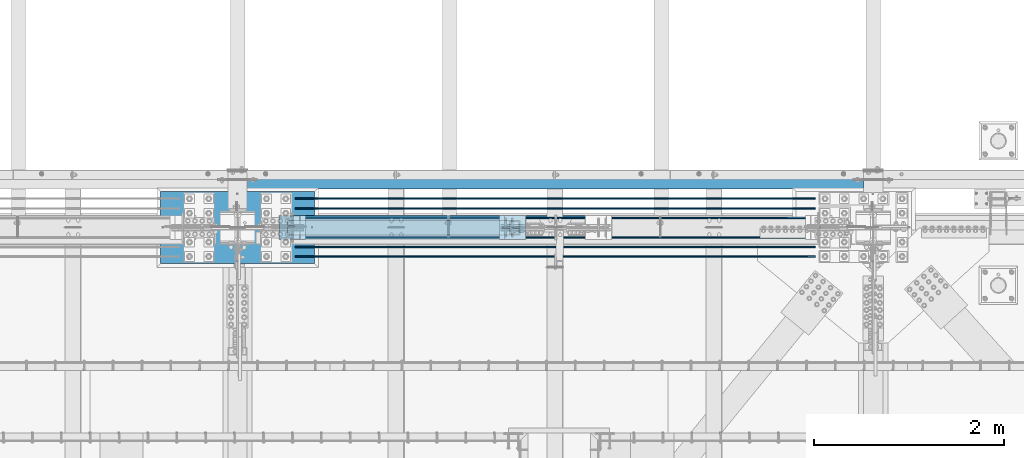
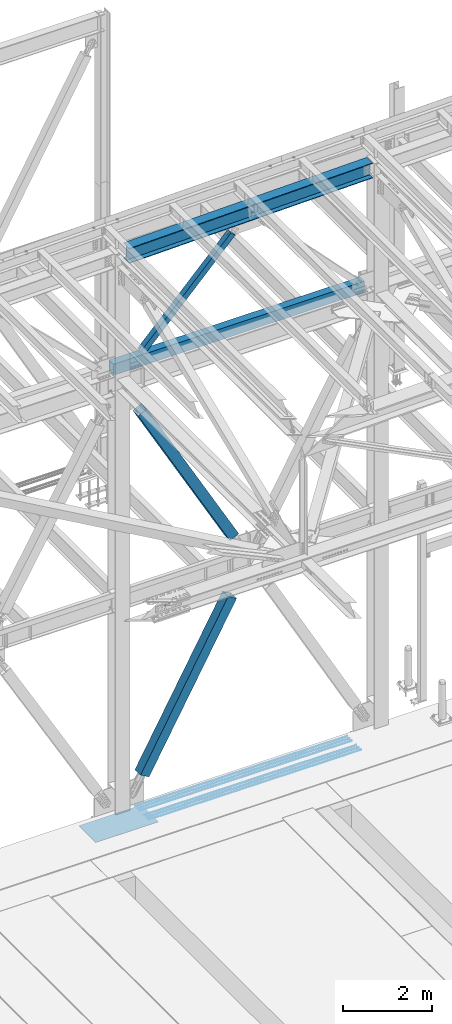
# One storey, part 1918 of 3843: 9 beams, 3 members, 12 elements without a shape of their own.
"""IFC2X3 building model written with IfcOpenShell, lengths in millimetres."""

from ifc_helpers import new_model, si_unit, frame, origin_with_axes, place, context, subcontext, project, spatial, faceted_brep, material, type_object, element, aggregate, save


model = new_model("IFC2X3")

# Units and contexts
model_context = context("Model", 3, precision=1e-05, world=origin_with_axes())
body_context = subcontext(model_context, "Body", "Model", "MODEL_VIEW")
ifc_project = project(units=[si_unit("LENGTHUNIT", "METRE", prefix="MILLI"), si_unit("AREAUNIT", "SQUARE_METRE"), si_unit("VOLUMEUNIT", "CUBIC_METRE"), si_unit("MASSUNIT", "GRAM", prefix="KILO"), si_unit("TIMEUNIT", "SECOND"), si_unit("PLANEANGLEUNIT", "RADIAN"), si_unit("SOLIDANGLEUNIT", "STERADIAN"), si_unit("THERMODYNAMICTEMPERATUREUNIT", "DEGREE_CELSIUS"), si_unit("LUMINOUSINTENSITYUNIT", "LUMEN")], contexts=[model_context])

# Site, building, storey
site_placement = place(None, origin_with_axes())
site = spatial("IfcSite", under=ifc_project, at=site_placement, CompositionType="ELEMENT")
building_placement = place(site_placement, origin_with_axes())
building = spatial("IfcBuilding", under=site, at=building_placement, Name="Undefined", CompositionType="ELEMENT")
storey_placement = place(building_placement, origin_with_axes())
storey = spatial("IfcBuildingStorey", under=building, at=storey_placement, Name="Undefined", CompositionType="ELEMENT", Elevation=0.0)

# Assembly, beam
assembly_1_placement = place(storey_placement, origin_with_axes())
assembly_1 = element("IfcElementAssembly", 1, at=assembly_1_placement, inside=storey, Name="REBAR", AssemblyPlace="NOTDEFINED", PredefinedType="RIGID_FRAME")
ifc_material_1 = material(Name="STEEL/A706-60")
beam_type_1 = type_object("IfcBeamType", Name="#10 REBAR", PredefinedType="NOTDEFINED")
beam_1_placement = place(assembly_1_placement, frame((56540.381606967, 91909.900012207, 30157.7375212653), z_axis=(0.00231477199979418, 0.0, 0.999997320911706), x_axis=(0.999997320911706, 0.0, -0.00231477199979557)))
beam_1 = element("IfcBeam", 2, at=beam_1_placement, type_object=beam_type_1, material=ifc_material_1, Name="REBAR", ObjectType="#10 REBAR", context=body_context, shape_type="Brep", body=[
    faceted_brep([(0.0, -7.9375, 0.0), (0.0, -5.61266007566883, -5.61266007566883), (5486.50219881769, -5.61266007566883, -5.61266006854567), (5486.50219881768, -7.9375, 7.12316250428557e-09), (0.0, 0.0, -7.9375), (5486.50219881769, 0.0, -7.93749999287684), (0.0, 5.61266007566883, -5.61266007566883), (5486.50219881769, 5.61266007566883, -5.61266006854567), (0.0, 7.9375, 0.0), (5486.50219881768, 7.9375, 7.12316250428557e-09), (0.0, 5.61266007566883, 5.61266007566883), (5486.50219881767, 5.61266007566883, 5.61266008279927), (0.0, 0.0, 7.9375), (5486.50219881767, 0.0, 7.93750000713408), (0.0, -5.61266007566883, 5.61266007566883), (5486.50219881767, -5.61266007566883, 5.61266008279927)], [[[0, 1, 2, 3]], [[1, 4, 5, 2]], [[4, 6, 7, 5]], [[6, 8, 9, 7]], [[8, 10, 11, 9]], [[10, 12, 13, 11]], [[12, 14, 15, 13]], [[14, 0, 3, 15]], [[5, 7, 9, 11, 13, 15, 3, 2]], [[14, 12, 10, 8, 6, 4, 1, 0]]]),
])
aggregate(assembly_1, [beam_1])

assembly_2_placement = place(storey_placement, origin_with_axes())
assembly_2 = element("IfcElementAssembly", 3, at=assembly_2_placement, inside=storey, Name="REBAR", AssemblyPlace="NOTDEFINED", PredefinedType="RIGID_FRAME")
beam_2_placement = place(assembly_2_placement, frame((56540.381606967, 92011.500012207, 30157.7375212653), z_axis=(0.00231477199979418, 0.0, 0.999997320911706), x_axis=(0.999997320911706, 0.0, -0.00231477199979557)))
beam_2 = element("IfcBeam", 4, at=beam_2_placement, type_object=beam_type_1, material=ifc_material_1, Name="REBAR", ObjectType="#10 REBAR", context=body_context, shape_type="Brep", body=[
    faceted_brep([(0.0, -7.9375, 0.0), (0.0, -5.61266007566883, -5.61266007566883), (5486.50219881769, -5.61266007566883, -5.61266006854567), (5486.50219881768, -7.9375, 7.12316250428557e-09), (0.0, 0.0, -7.9375), (5486.50219881769, 0.0, -7.93749999287684), (0.0, 5.61266007566883, -5.61266007566883), (5486.50219881769, 5.61266007566883, -5.61266006854567), (0.0, 7.9375, 0.0), (5486.50219881768, 7.9375, 7.12316250428557e-09), (0.0, 5.61266007566883, 5.61266007566883), (5486.50219881767, 5.61266007566883, 5.61266008279927), (0.0, 0.0, 7.9375), (5486.50219881767, 0.0, 7.93750000713408), (0.0, -5.61266007566883, 5.61266007566883), (5486.50219881767, -5.61266007566883, 5.61266008279927)], [[[0, 1, 2, 3]], [[1, 4, 5, 2]], [[4, 6, 7, 5]], [[6, 8, 9, 7]], [[8, 10, 11, 9]], [[10, 12, 13, 11]], [[12, 14, 15, 13]], [[14, 0, 3, 15]], [[5, 7, 9, 11, 13, 15, 3, 2]], [[14, 12, 10, 8, 6, 4, 1, 0]]]),
])
aggregate(assembly_2, [beam_2])

assembly_3_placement = place(storey_placement, origin_with_axes())
assembly_3 = element("IfcElementAssembly", 5, at=assembly_3_placement, inside=storey, Name="REBAR", AssemblyPlace="NOTDEFINED", PredefinedType="RIGID_FRAME")
beam_3_placement = place(assembly_3_placement, frame((56540.381606967, 92113.100012207, 30157.7375212653), z_axis=(0.00231477199979418, 0.0, 0.999997320911706), x_axis=(0.999997320911706, 0.0, -0.00231477199979557)))
beam_3 = element("IfcBeam", 6, at=beam_3_placement, type_object=beam_type_1, material=ifc_material_1, Name="REBAR", ObjectType="#10 REBAR", context=body_context, shape_type="Brep", body=[
    faceted_brep([(0.0, -7.9375, 0.0), (0.0, -5.61266007566883, -5.61266007566883), (5486.50219881769, -5.61266007566883, -5.61266006854567), (5486.50219881768, -7.9375, 7.12316250428557e-09), (0.0, 0.0, -7.9375), (5486.50219881769, 0.0, -7.93749999287684), (0.0, 5.61266007566883, -5.61266007566883), (5486.50219881769, 5.61266007566883, -5.61266006854567), (0.0, 7.9375, 0.0), (5486.50219881768, 7.9375, 7.12316250428557e-09), (0.0, 5.61266007566883, 5.61266007566883), (5486.50219881767, 5.61266007566883, 5.61266008279927), (0.0, 0.0, 7.9375), (5486.50219881767, 0.0, 7.93750000713408), (0.0, -5.61266007566883, 5.61266007566883), (5486.50219881767, -5.61266007566883, 5.61266008279927)], [[[0, 1, 2, 3]], [[1, 4, 5, 2]], [[4, 6, 7, 5]], [[6, 8, 9, 7]], [[8, 10, 11, 9]], [[10, 12, 13, 11]], [[12, 14, 15, 13]], [[14, 0, 3, 15]], [[5, 7, 9, 11, 13, 15, 3, 2]], [[14, 12, 10, 8, 6, 4, 1, 0]]]),
])
aggregate(assembly_3, [beam_3])

assembly_4_placement = place(storey_placement, origin_with_axes())
assembly_4 = element("IfcElementAssembly", 7, at=assembly_4_placement, inside=storey, Name="REBAR", AssemblyPlace="NOTDEFINED", PredefinedType="RIGID_FRAME")
beam_4_placement = place(assembly_4_placement, frame((56540.381606967, 92519.500012207, 30157.7375212653), z_axis=(0.00231477199979418, 0.0, 0.999997320911706), x_axis=(0.999997320911706, 0.0, -0.00231477199979557)))
beam_4 = element("IfcBeam", 8, at=beam_4_placement, type_object=beam_type_1, material=ifc_material_1, Name="REBAR", ObjectType="#10 REBAR", context=body_context, shape_type="Brep", body=[
    faceted_brep([(0.0, -7.9375, 0.0), (0.0, -5.61266007566883, -5.61266007566883), (5486.50219881769, -5.61266007566883, -5.61266006854567), (5486.50219881768, -7.9375, 7.12316250428557e-09), (0.0, 0.0, -7.9375), (5486.50219881769, 0.0, -7.93749999287684), (0.0, 5.61266007566883, -5.61266007566883), (5486.50219881769, 5.61266007566883, -5.61266006854567), (0.0, 7.9375, 0.0), (5486.50219881768, 7.9375, 7.12316250428557e-09), (0.0, 5.61266007566883, 5.61266007566883), (5486.50219881767, 5.61266007566883, 5.61266008279927), (0.0, 0.0, 7.9375), (5486.50219881767, 0.0, 7.93750000713408), (0.0, -5.61266007566883, 5.61266007566883), (5486.50219881767, -5.61266007566883, 5.61266008279927)], [[[0, 1, 2, 3]], [[1, 4, 5, 2]], [[4, 6, 7, 5]], [[6, 8, 9, 7]], [[8, 10, 11, 9]], [[10, 12, 13, 11]], [[12, 14, 15, 13]], [[14, 0, 3, 15]], [[5, 7, 9, 11, 13, 15, 3, 2]], [[14, 12, 10, 8, 6, 4, 1, 0]]]),
])
aggregate(assembly_4, [beam_4])

assembly_5_placement = place(storey_placement, origin_with_axes())
assembly_5 = element("IfcElementAssembly", 9, at=assembly_5_placement, inside=storey, Name="REBAR", AssemblyPlace="NOTDEFINED", PredefinedType="RIGID_FRAME")
beam_5_placement = place(assembly_5_placement, frame((56540.381606967, 92417.900012207, 30157.7375212653), z_axis=(0.00231477199979418, 0.0, 0.999997320911706), x_axis=(0.999997320911706, 0.0, -0.00231477199979557)))
beam_5 = element("IfcBeam", 10, at=beam_5_placement, type_object=beam_type_1, material=ifc_material_1, Name="REBAR", ObjectType="#10 REBAR", context=body_context, shape_type="Brep", body=[
    faceted_brep([(0.0, -7.9375, 0.0), (0.0, -5.61266007566883, -5.61266007566883), (5486.50219881769, -5.61266007566883, -5.61266006854567), (5486.50219881768, -7.9375, 7.12316250428557e-09), (0.0, 0.0, -7.9375), (5486.50219881769, 0.0, -7.93749999287684), (0.0, 5.61266007566883, -5.61266007566883), (5486.50219881769, 5.61266007566883, -5.61266006854567), (0.0, 7.9375, 0.0), (5486.50219881768, 7.9375, 7.12316250428557e-09), (0.0, 5.61266007566883, 5.61266007566883), (5486.50219881767, 5.61266007566883, 5.61266008279927), (0.0, 0.0, 7.9375), (5486.50219881767, 0.0, 7.93750000713408), (0.0, -5.61266007566883, 5.61266007566883), (5486.50219881767, -5.61266007566883, 5.61266008279927)], [[[0, 1, 2, 3]], [[1, 4, 5, 2]], [[4, 6, 7, 5]], [[6, 8, 9, 7]], [[8, 10, 11, 9]], [[10, 12, 13, 11]], [[12, 14, 15, 13]], [[14, 0, 3, 15]], [[5, 7, 9, 11, 13, 15, 3, 2]], [[14, 12, 10, 8, 6, 4, 1, 0]]]),
])
aggregate(assembly_5, [beam_5])

assembly_6_placement = place(storey_placement, origin_with_axes())
assembly_6 = element("IfcElementAssembly", 11, at=assembly_6_placement, inside=storey, Name="REBAR", AssemblyPlace="NOTDEFINED", PredefinedType="RIGID_FRAME")
beam_6_placement = place(assembly_6_placement, frame((56540.381606967, 92316.300012207, 30157.7375212653), z_axis=(0.00231477199979418, 0.0, 0.999997320911706), x_axis=(0.999997320911706, 0.0, -0.00231477199979557)))
beam_6 = element("IfcBeam", 12, at=beam_6_placement, type_object=beam_type_1, material=ifc_material_1, Name="REBAR", ObjectType="#10 REBAR", context=body_context, shape_type="Brep", body=[
    faceted_brep([(0.0, -7.9375, 0.0), (0.0, -5.61266007566883, -5.61266007566883), (5486.50219881769, -5.61266007566883, -5.61266006854567), (5486.50219881768, -7.9375, 7.12316250428557e-09), (0.0, 0.0, -7.9375), (5486.50219881769, 0.0, -7.93749999287684), (0.0, 5.61266007566883, -5.61266007566883), (5486.50219881769, 5.61266007566883, -5.61266006854567), (0.0, 7.9375, 0.0), (5486.50219881768, 7.9375, 7.12316250428557e-09), (0.0, 5.61266007566883, 5.61266007566883), (5486.50219881767, 5.61266007566883, 5.61266008279927), (0.0, 0.0, 7.9375), (5486.50219881767, 0.0, 7.93750000713408), (0.0, -5.61266007566883, 5.61266007566883), (5486.50219881767, -5.61266007566883, 5.61266008279927)], [[[0, 1, 2, 3]], [[1, 4, 5, 2]], [[4, 6, 7, 5]], [[6, 8, 9, 7]], [[8, 10, 11, 9]], [[10, 12, 13, 11]], [[12, 14, 15, 13]], [[14, 0, 3, 15]], [[5, 7, 9, 11, 13, 15, 3, 2]], [[14, 12, 10, 8, 6, 4, 1, 0]]]),
])
aggregate(assembly_6, [beam_6])

assembly_7_placement = place(storey_placement, origin_with_axes())
assembly_7 = element("IfcElementAssembly", 13, at=assembly_7_placement, inside=storey, Name="GIRT", AssemblyPlace="NOTDEFINED", PredefinedType="RIGID_FRAME")
ifc_material_2 = material()
beam_type_2 = type_object("IfcBeamType", Name="HSS12X8X3/8", PredefinedType="NOTDEFINED")
beam_7_placement = place(assembly_7_placement, frame((55930.8, 92722.7, 42214.8), z_axis=(0.0, 0.0, 1.0), x_axis=(1.0, 0.0, 0.0)))
beam_7 = element("IfcBeam", 14, at=beam_7_placement, type_object=beam_type_2, material=ifc_material_2, Name="GIRT", ObjectType="HSS12X8X3/8", context=body_context, shape_type="Brep", body=[
    faceted_brep([(103.1875, 101.600000000006, -152.400000000001), (103.1875, 101.600000000006, 152.400000000001), (6602.41250000001, 101.600000000006, 152.400000000001), (6602.41250000001, 101.600000000006, -152.400000000001), (103.1875, -101.600000000006, -152.400000000001), (6602.41250000001, -101.600000000006, -152.400000000001), (103.1875, -101.600000000006, 152.400000000001), (6602.41250000001, -101.600000000006, 152.400000000001), (103.1875, 92.0749999999971, -142.875), (103.1875, 92.0749999999971, 142.875), (103.1875, -92.0749999999971, 142.875), (103.1875, -92.0749999999971, -142.875), (6602.41250000001, -92.0749999999971, 142.875), (6602.41250000001, -92.0749999999971, -142.875), (6602.41250000001, 92.0749999999971, -142.875), (6602.41250000001, 92.0749999999971, 142.875)], [[[0, 1, 2, 3]], [[4, 0, 3, 5]], [[6, 4, 5, 7]], [[1, 6, 7, 2]], [[0, 4, 6, 1], [8, 9, 10, 11]], [[11, 10, 12, 13]], [[8, 11, 13, 14]], [[9, 8, 14, 15]], [[10, 9, 15, 12]], [[3, 2, 7, 5], [14, 13, 12, 15]]]),
])
aggregate(assembly_7, [beam_7])

# Assembly, member
assembly_8_placement = place(storey_placement, origin_with_axes())
assembly_8 = element("IfcElementAssembly", 15, at=assembly_8_placement, inside=storey, Name="None", AssemblyPlace="NOTDEFINED", PredefinedType="RIGID_FRAME")
ifc_material_3 = material(Name="STEEL/A992")
member_type_1 = type_object("IfcMemberType", Name="HSS10X10X1/4", PredefinedType="NOTDEFINED")
member_1_placement = place(assembly_8_placement, frame((58857.4161373721, 92214.7, 36964.9838076808), z_axis=(0.0, 1.0, 0.0), x_axis=(-0.488113231172773, 0.0, 0.872780312308931)))
member_1 = element("IfcMember", 16, at=member_1_placement, type_object=member_type_1, material=ifc_material_3, Name="None", ObjectType="HSS10X10X1/4", context=body_context, shape_type="Brep", body=[
    faceted_brep([(2.00088834390044e-10, 120.650000000089, -120.649999999994), (-2.03726813197136e-10, -120.650000000081, -120.649999999994), (4870.45000005738, -120.649999988149, -120.649999999994), (4870.45000005679, 120.650000012101, -120.649999999994), (-2.03726813197136e-10, -120.650000000081, 120.649999999994), (4870.45000005738, -120.649999988149, 120.649999999994), (2.00088834390044e-10, 120.650000000089, 120.649999999994), (4870.45000005679, 120.650000012101, 120.649999999994), (2.16459739021957e-10, 127.000000000087, -127.0), (2.16459739021957e-10, 127.000000000087, 127.0), (4870.45000005677, 127.000000012122, 127.0), (4870.45000005677, 127.000000012122, -127.0), (-2.14640749618411e-10, -127.00000000008, 127.0), (4870.4500000574, -126.999999988155, 127.0), (-2.14640749618411e-10, -127.00000000008, -127.0), (4870.4500000574, -126.999999988155, -127.0)], [[[0, 1, 2, 3]], [[1, 4, 5, 2]], [[4, 6, 7, 5]], [[6, 0, 3, 7]], [[8, 9, 10, 11]], [[9, 12, 13, 10]], [[12, 14, 15, 13]], [[14, 8, 11, 15]], [[13, 15, 11, 10], [5, 7, 3, 2]], [[14, 12, 9, 8], [6, 4, 1, 0]]]),
])
aggregate(assembly_8, [member_1])

assembly_9_placement = place(storey_placement, origin_with_axes())
assembly_9 = element("IfcElementAssembly", 17, at=assembly_9_placement, inside=storey, Name="None", AssemblyPlace="NOTDEFINED", PredefinedType="RIGID_FRAME")
member_2_placement = place(assembly_9_placement, frame((56535.387215783, 92214.7, 31241.3203842047), z_axis=(0.0, -1.0, 0.0), x_axis=(0.484532240013288, 0.0, 0.874773404023982)))
member_2 = element("IfcMember", 18, at=member_2_placement, type_object=member_type_1, material=ifc_material_3, Name="None", ObjectType="HSS10X10X1/4", context=body_context, shape_type="Brep", body=[
    faceted_brep([(2.00088834390044e-10, 120.650000000089, -120.649999999994), (-2.03726813197136e-10, -120.650000000081, -120.649999999994), (4679.95000001111, -120.650000007008, -120.649999999994), (4679.95000001146, 120.649999992798, -120.649999999994), (-2.03726813197136e-10, -120.650000000081, 120.649999999994), (4679.95000001111, -120.650000007008, 120.649999999994), (2.00088834390044e-10, 120.650000000089, 120.649999999994), (4679.95000001146, 120.649999992798, 120.649999999994), (2.16459739021957e-10, 127.000000000087, -127.0), (2.16459739021957e-10, 127.000000000087, 127.0), (4679.95000001148, 126.999999992797, 127.0), (4679.95000001148, 126.999999992797, -127.0), (-2.14640749618411e-10, -127.00000000008, 127.0), (4679.9500000111, -127.000000007007, 127.0), (-2.14640749618411e-10, -127.00000000008, -127.0), (4679.9500000111, -127.000000007007, -127.0)], [[[0, 1, 2, 3]], [[1, 4, 5, 2]], [[4, 6, 7, 5]], [[6, 0, 3, 7]], [[8, 9, 10, 11]], [[9, 12, 13, 10]], [[12, 14, 15, 13]], [[14, 8, 11, 15]], [[13, 15, 11, 10], [5, 7, 3, 2]], [[14, 12, 9, 8], [6, 4, 1, 0]]]),
])
aggregate(assembly_9, [member_2])

assembly_10_placement = place(storey_placement, origin_with_axes())
assembly_10 = element("IfcElementAssembly", 19, at=assembly_10_placement, inside=storey, AssemblyPlace="NOTDEFINED", PredefinedType="RIGID_FRAME")
member_type_2 = type_object("IfcMemberType", Name="HSS6X6X3/8", PredefinedType="NOTDEFINED")
member_3_placement = place(assembly_10_placement, frame((55930.7999983949, 92214.6999999811, 42197.337498318), z_axis=(0.721481345122366, 0.0, -0.692433873117442), x_axis=(0.692433873117446, 0.0, 0.721481345122362)))
member_3 = element("IfcMember", 20, at=member_3_placement, type_object=member_type_2, material=ifc_material_2, ObjectType="HSS6X6X3/8", context=body_context, shape_type="Brep", body=[
    faceted_brep([(4219.59950864415, 7.9375, 76.2000000078933), (4119.58700864414, 7.9375, 76.2000000077114), (4119.58700864417, 7.9375, 66.6750000077063), (4219.59950864415, 7.9375, 66.6750000078991), (4116.54945889975, 7.33329378931376, 76.2000000077041), (4116.54945889977, 7.33329378931376, 66.6750000077063), (4113.97434856847, 5.61266007566883, 76.2000000076932), (4113.97434856849, 5.61266007566883, 66.6750000076991), (4112.25371485483, 3.0375497444038, 76.2000000076896), (4112.25371485486, 3.0375497444038, 66.6750000076918), (4111.64950864414, 0.0, 76.2000000076932), (4111.64950864416, 0.0, 66.6750000076881), (4112.25371485483, -3.0375497444038, 76.2000000076896), (4112.25371485486, -3.0375497444038, 66.6750000076918), (4113.97434856847, -5.61266007566883, 76.2000000076932), (4113.97434856849, -5.61266007566883, 66.6750000076991), (4116.54945889975, -7.33329378931376, 76.2000000077041), (4116.54945889977, -7.33329378931376, 66.6750000077063), (4119.58700864414, -7.9375, 76.2000000077114), (4119.58700864417, -7.9375, 66.6750000077063), (4219.59950864415, -7.9375, 76.2000000078933), (4219.59950864415, -7.9375, 66.6750000078991), (4219.59950864417, 7.9375, -66.6749999920958), (4119.5870086444, 7.9375, -66.6749999922777), (4119.58700864443, 7.9375, -76.1999999922755), (4219.59950864415, 7.9375, -76.1999999920972), (4116.54945890002, 7.33329378931376, -66.6749999922849), (4116.54945890003, 7.33329378931376, -76.1999999922828), (4113.97434856875, 5.61266007566883, -66.6749999922849), (4113.97434856876, 5.61266007566883, -76.19999999229), (4112.25371485511, 3.0375497444038, -66.6749999922922), (4112.25371485512, 3.0375497444038, -76.19999999229), (4111.6495086444, 0.0, -66.6749999922922), (4111.64950864443, 0.0, -76.19999999229), (4112.25371485511, -3.0375497444038, -66.6749999922922), (4112.25371485512, -3.0375497444038, -76.19999999229), (4113.97434856875, -5.61266007566883, -66.6749999922849), (4113.97434856876, -5.61266007566883, -76.19999999229), (4116.54945890002, -7.33329378931376, -66.6749999922849), (4116.54945890003, -7.33329378931376, -76.1999999922828), (4119.5870086444, -7.9375, -66.6749999922777), (4119.58700864443, -7.9375, -76.1999999922755), (4219.59950864417, -7.9375, -66.6749999920958), (4219.59950864415, -7.9375, -76.1999999920972), (840.293354128517, 66.6750000000029, 66.6750000015727), (840.293354128502, 66.6750000000029, -66.6749999984186), (4219.59950864417, 66.6750000000029, -66.6749999920958), (4219.59950864415, 66.6750000000029, 66.6750000078991), (4219.59950864415, -66.6750000000029, 66.6750000078991), (840.293354128517, -66.6750000000029, 66.6750000015727), (840.293354128517, -20.6374999999971, 66.6750000015727), (940.305854130318, -20.6374999999971, 66.675000001751), (943.343403874722, -20.0332937893108, 66.6750000017582), (945.918514205987, -18.3126600756659, 66.6750000017619), (947.639147919617, -15.7375497444009, 66.6750000017728), (948.243354130318, -12.6999999999971, 66.6750000017728), (947.639147919617, -9.66245025559328, 66.6750000017728), (945.918514205987, -7.08733992432826, 66.6750000017619), (943.343403874722, -5.36670621068333, 66.6750000017582), (940.305854130318, -4.76249999999709, 66.675000001751), (840.293354128517, -4.76249999999709, 66.6750000015727), (840.293354128502, -66.6750000000029, -66.6749999984186), (4219.59950864417, -66.6750000000029, -66.6749999920958), (840.293354128502, -4.76249999999709, -66.6749999984186), (940.305854130565, -4.76249999999709, -66.6749999982294), (943.343403874969, -5.36670621068333, -66.6749999982221), (945.918514206234, -7.08733992432826, -66.6749999982185), (947.639147919879, -9.66245025559328, -66.6749999982148), (948.24335413058, -12.6999999999971, -66.6749999982112), (947.639147919879, -15.7375497444009, -66.6749999982148), (945.918514206234, -18.3126600756659, -66.6749999982185), (943.343403874969, -20.0332937893108, -66.6749999982221), (940.305854130565, -20.6374999999971, -66.6749999982294), (840.293354128502, -20.6374999999971, -66.6749999984186), (840.293354128517, -4.76249999999709, -76.1999999984164), (940.30585413058, -4.76249999999709, -76.1999999982272), (943.343403874984, -5.36670621068333, -76.1999999982272), (945.918514206263, -7.08733992432826, -76.1999999982163), (947.639147919908, -9.66245025559328, -76.1999999982127), (948.243354130595, -12.6999999999971, -76.199999998209), (947.639147919908, -15.7375497444009, -76.1999999982127), (945.918514206263, -18.3126600756659, -76.1999999982163), (943.343403874984, -20.0332937893108, -76.1999999982272), (940.30585413058, -20.6374999999971, -76.1999999982272), (840.293354128517, -20.6374999999971, -76.1999999984164), (840.293354128517, -76.1999999999971, -76.1999999984164), (840.293354128517, -76.1999999999971, 76.2000000015669), (840.293354128517, -20.6374999999971, 76.2000000015669), (940.305854130318, -20.6374999999971, 76.2000000017561), (943.343403874707, -20.0332937893108, 76.2000000017561), (945.918514205972, -18.3126600756659, 76.200000001767), (947.639147919617, -15.7375497444009, 76.2000000017706), (948.243354130303, -12.6999999999971, 76.200000001767), (947.639147919617, -9.66245025559328, 76.2000000017706), (945.918514205972, -7.08733992432826, 76.200000001767), (943.343403874707, -5.36670621068333, 76.2000000017561), (940.305854130318, -4.76249999999709, 76.2000000017561), (840.293354128517, -4.76249999999709, 76.2000000015669), (840.293354128517, 76.1999999999971, 76.2000000015669), (840.293354128517, 76.1999999999971, -76.1999999984164), (4219.59950864415, 76.1999999999971, 76.2000000078933), (4219.59950864415, 76.1999999999971, -76.1999999920972), (4219.59950864415, -76.1999999999971, -76.1999999920972), (4219.59950864415, -76.1999999999971, 76.2000000078933)], [[[0, 1, 2, 3]], [[4, 5, 2, 1]], [[6, 7, 5, 4]], [[8, 9, 7, 6]], [[10, 11, 9, 8]], [[12, 13, 11, 10]], [[14, 15, 13, 12]], [[16, 17, 15, 14]], [[18, 19, 17, 16]], [[20, 21, 19, 18]], [[22, 23, 24, 25]], [[26, 27, 24, 23]], [[28, 29, 27, 26]], [[30, 31, 29, 28]], [[32, 33, 31, 30]], [[34, 35, 33, 32]], [[36, 37, 35, 34]], [[38, 39, 37, 36]], [[40, 41, 39, 38]], [[42, 43, 41, 40]], [[44, 45, 46, 47]], [[48, 49, 50, 51, 52, 53, 54, 55, 56, 57, 58, 59, 60, 44, 47, 3, 2, 5, 7, 9, 11, 13, 15, 17, 19, 21]], [[61, 49, 48, 62]], [[38, 36, 34, 32, 30, 28, 26, 23, 22, 46, 45, 63, 64, 65, 66, 67, 68, 69, 70, 71, 72, 73, 61, 62, 42, 40]], [[63, 74, 75, 64]], [[64, 75, 76, 65]], [[65, 76, 77, 66]], [[66, 77, 78, 67]], [[67, 78, 79, 68]], [[68, 79, 80, 69]], [[69, 80, 81, 70]], [[70, 81, 82, 71]], [[71, 82, 83, 72]], [[72, 83, 84, 73]], [[49, 61, 73, 84, 85, 86, 87, 50]], [[88, 51, 50, 87]], [[89, 52, 51, 88]], [[90, 53, 52, 89]], [[91, 54, 53, 90]], [[92, 55, 54, 91]], [[93, 56, 55, 92]], [[94, 57, 56, 93]], [[95, 58, 57, 94]], [[96, 59, 58, 95]], [[97, 60, 59, 96]], [[98, 99, 74, 63, 45, 44, 60, 97]], [[99, 98, 100, 101]], [[47, 46, 22, 25, 101, 100, 0, 3]], [[102, 85, 84, 83, 82, 81, 80, 79, 78, 77, 76, 75, 74, 99, 101, 25, 24, 27, 29, 31, 33, 35, 37, 39, 41, 43]], [[86, 85, 102, 103]], [[16, 14, 12, 10, 8, 6, 4, 1, 0, 100, 98, 97, 96, 95, 94, 93, 92, 91, 90, 89, 88, 87, 86, 103, 20, 18]], [[103, 102, 43, 42, 62, 48, 21, 20]]]),
])
aggregate(assembly_10, [member_3])

# Assembly, beam
assembly_11_placement = place(storey_placement, origin_with_axes())
assembly_11 = element("IfcElementAssembly", 21, at=assembly_11_placement, inside=storey, Name="BEAM", AssemblyPlace="NOTDEFINED", PredefinedType="RIGID_FRAME")
beam_type_3 = type_object("IfcBeamType", Name="W16X67", PredefinedType="NOTDEFINED")
beam_8_placement = place(assembly_11_placement, frame((55935.1988430288, 92214.7, 45619.9452773378), z_axis=(-0.0211520980073474, 0.0, 0.999776269347241), x_axis=(0.999776270257024, 0.0, 0.0211520550054619)))
beam_8 = element("IfcBeam", 22, at=beam_8_placement, type_object=beam_type_3, material=ifc_material_3, Name="BEAM", ObjectType="W16X67", context=body_context, shape_type="Brep", body=[
    faceted_brep([(188.094396478875, -130.174999999999, -207.962499999492), (188.094396478875, 130.174999999999, -207.962499999492), (6501.40687772939, 130.174999999999, -207.962499993126), (6501.40687772939, -130.174999999999, -207.962499993126), (188.463847647872, -130.174999999999, -190.49999999952), (188.463847647872, -4.76250000000073, -190.49999999952), (189.242288995723, -4.76249999999709, -153.706144372947), (195.989385218127, -4.76249999999709, 165.202490022399), (196.524600426201, -4.76250000000073, 190.499999999869), (196.524600426201, -130.174999999999, 190.499999999869), (196.894051595213, -130.174999999999, 207.962499999841), (196.894051595213, 130.174999999999, 207.962499999841), (196.524600426201, 130.174999999999, 190.499999999869), (196.524600426201, 4.76250000000073, 190.499999999869), (188.463847647872, 4.76250000000073, -190.49999999952), (188.463847647872, 130.174999999999, -190.49999999952), (6501.77632889838, -130.174999999999, -190.499999993161), (6501.77632889838, -4.76250000000073, -190.499999993161), (6502.51498645643, -4.76249999999709, -155.586565882797), (6509.26208267879, -4.76249999999709, 163.322068512549), (6509.83708167665, -4.76250000000073, 190.500000006235), (6509.83708167665, -130.174999999999, 190.500000006235), (6510.20653284565, -130.174999999999, 207.962500006208), (6510.20653284565, 130.174999999999, 207.962500006208), (6509.83708167665, 130.174999999999, 190.500000006235), (6509.83708167665, 4.76250000000073, 190.500000006235), (6501.77632889838, 4.76250000000073, -190.499999993161), (6501.77632889838, 130.174999999999, -190.499999993161)], [[[0, 1, 2, 3]], [[0, 4, 5, 6, 7, 8, 9, 10, 11, 12, 13, 14, 15, 1]], [[5, 4, 16, 17]], [[8, 7, 6, 5, 17, 18, 19, 20]], [[9, 8, 20, 21]], [[10, 9, 21, 22]], [[11, 10, 22, 23]], [[12, 11, 23, 24]], [[13, 12, 24, 25]], [[14, 13, 25, 26]], [[15, 14, 26, 27]], [[1, 15, 27, 2]], [[26, 25, 24, 23, 22, 21, 20, 19, 18, 17, 16, 3, 2, 27]], [[4, 0, 3, 16]]]),
])
aggregate(assembly_11, [beam_8])

assembly_12_placement = place(storey_placement, origin_with_axes())
assembly_12 = element("IfcElementAssembly", 23, at=assembly_12_placement, inside=storey, Name="TEMPLATE", AssemblyPlace="NOTDEFINED", PredefinedType="RIGID_FRAME")
ifc_material_4 = material(Name="STEEL/A572-50")
beam_type_4 = type_object("IfcBeamType", PredefinedType="NOTDEFINED")
beam_9_placement = place(assembly_12_placement, frame((55930.8, 91833.7000030518, 30065.6625), z_axis=(-1.0, 0.0, 0.0), x_axis=(0.0, 1.0, 0.0)))
beam_9 = element("IfcBeam", 24, at=beam_9_placement, type_object=beam_type_4, material=ifc_material_4, Name="TEMPLATE", context=body_context, shape_type="Brep", body=[
    faceted_brep([(0.0, 4.76250000000073, -812.800000000003), (0.0, 4.76250000000073, 812.800000000003), (761.99999389649, 4.76250000000073, 812.800000000003), (761.99999389649, 4.76250000000073, -812.800000000003), (0.0, -4.76250000000073, 812.800000000003), (761.99999389649, -4.76250000000073, 812.800000000003), (0.0, -4.76250000000073, -812.800000000003), (761.99999389649, -4.76250000000073, -812.800000000003)], [[[0, 1, 2, 3]], [[1, 4, 5, 2]], [[4, 6, 7, 5]], [[6, 0, 3, 7]], [[5, 7, 3, 2]], [[6, 4, 1, 0]]]),
])
aggregate(assembly_12, [beam_9])

save(model, "model.ifc")
